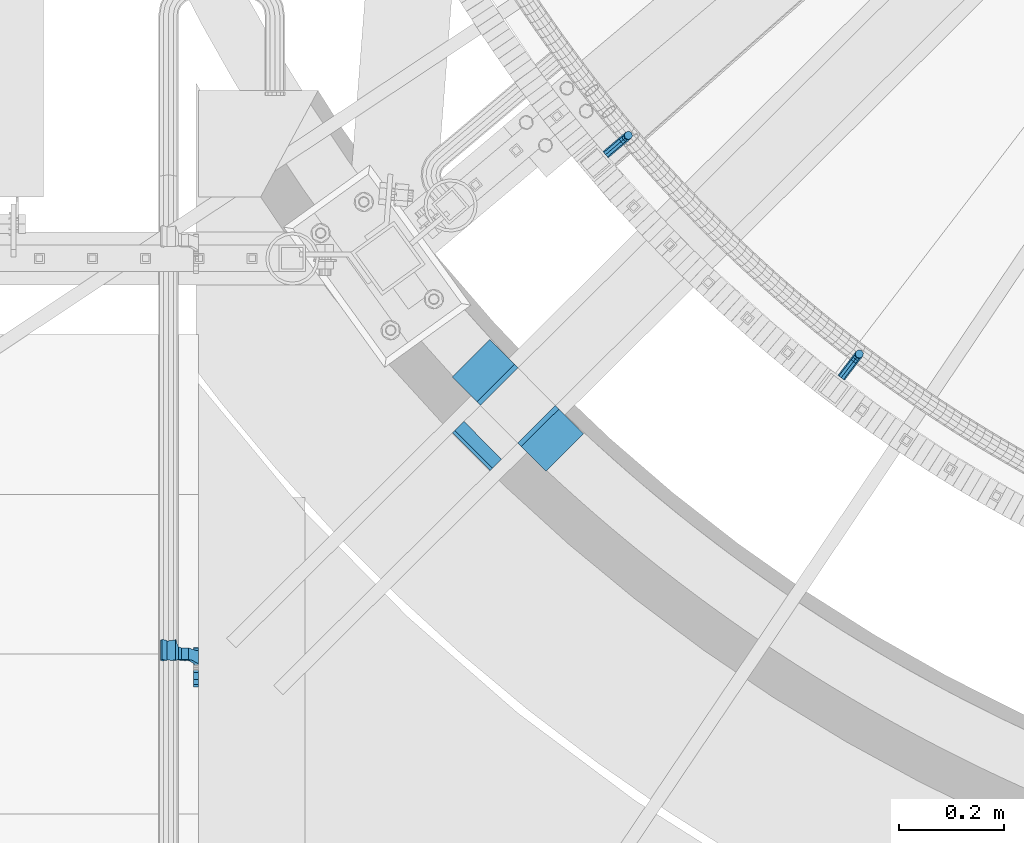
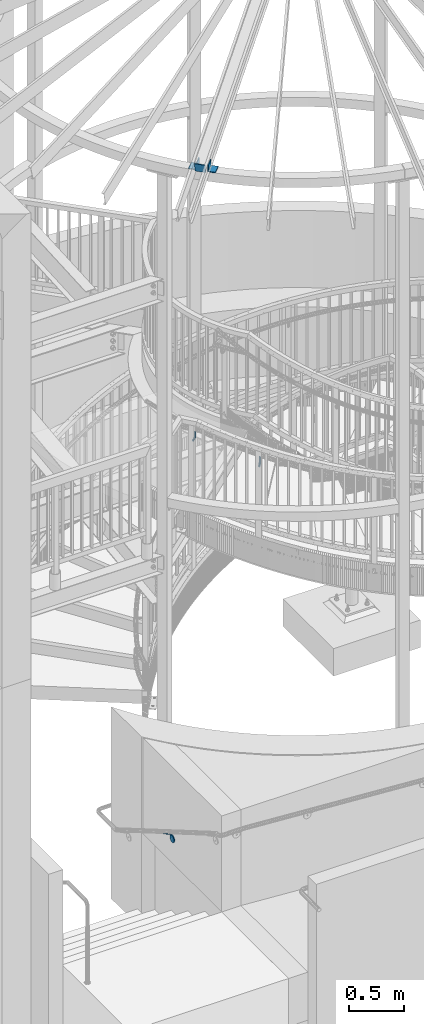
# One storey, part 461 of 975: 5 beams, 1 member.
"""IFC2X3 building model written with IfcOpenShell, lengths in millimetres."""

from ifc_helpers import new_model, si_unit, frame, origin_with_axes, place, context, subcontext, project, spatial, faceted_brep, material, type_object, element, save


model = new_model("IFC2X3")

# Units and contexts
model_context = context("Model", 3, precision=1e-05, world=origin_with_axes())
body_context = subcontext(model_context, "Body", "Model", "MODEL_VIEW")
ifc_project = project(units=[si_unit("LENGTHUNIT", "METRE", prefix="MILLI"), si_unit("AREAUNIT", "SQUARE_METRE"), si_unit("VOLUMEUNIT", "CUBIC_METRE"), si_unit("MASSUNIT", "GRAM", prefix="KILO"), si_unit("TIMEUNIT", "SECOND"), si_unit("PLANEANGLEUNIT", "RADIAN"), si_unit("SOLIDANGLEUNIT", "STERADIAN"), si_unit("THERMODYNAMICTEMPERATUREUNIT", "DEGREE_CELSIUS"), si_unit("LUMINOUSINTENSITYUNIT", "LUMEN")], contexts=[model_context])

# Site, building, storey
site_placement = place(None, origin_with_axes())
site = spatial("IfcSite", under=ifc_project, at=site_placement, CompositionType="ELEMENT")
building_placement = place(site_placement, origin_with_axes())
building = spatial("IfcBuilding", under=site, at=building_placement, Name="Undefined", CompositionType="ELEMENT")
storey_placement = place(building_placement, origin_with_axes())
storey = spatial("IfcBuildingStorey", under=building, at=storey_placement, Name="Undefined", CompositionType="ELEMENT", Elevation=0.0)

# Beams
ifc_material = material(Name="STEEL/A36")
beam_type_1 = type_object("IfcBeamType", PredefinedType="NOTDEFINED")
beam_1_placement = place(storey_placement, frame((32565.4851462999, 1562.87687980084, 4902.20901031494), z_axis=(0.0, 0.0, 1.0), x_axis=(0.762764145918276, 0.646676779930719, 0.0)))
element("IfcBeam", 1, at=beam_1_placement, inside=storey, type_object=beam_type_1, material=ifc_material, Name="BRACKET", context=body_context, shape_type="Brep", body=[
    faceted_brep([(-4.22995071858168e-07, -7.93750000000728, 0.0), (-2.99107341561466e-07, -5.61266007567065, -5.61266007566792), (31.7499842270954, -5.6126618385606, -5.6126600757234), (31.7499840980236, -7.93750176289177, -5.54791768081486e-11), (-1.09139364212751e-11, 1.81898940354586e-12, -7.9375), (31.7499845387247, -1.7628881323617e-06, -7.93750000005548), (2.99089151667431e-07, 5.61266007567428, -5.61266007566792), (31.7499848503612, 5.61265831278433, -5.6126600757234), (4.22980519942939e-07, 7.93750000001091, 0.0), (31.7499849794513, 7.93749823711914, -5.54791768081486e-11), (2.99089151667431e-07, 5.61266007567428, 5.61266007566792), (31.7499848503794, 5.61265831278433, 5.61266007561244), (-1.09139364212751e-11, 1.81898940354586e-12, 7.9375), (31.7499845387538, -1.7628881323617e-06, 7.93749999994452), (-2.99107341561466e-07, -5.61266007567065, 5.61266007566792), (31.7499842271172, -5.6126618385606, 5.61266007561244), (44.5076933192395, -2.47124626184814e-06, -5.39983394420233), (43.618015285665, -5.61266249752225, -3.25196192174644), (41.4701431341346, -7.93750230259684, 1.9334598451087), (39.322271240766, -5.61266225900181, 7.11888161196475), (38.432593830461, -2.1339365048334e-06, 9.26675363442064), (39.3222718640282, 5.61265789233948, 7.11888161196475), (41.4701440155623, 7.93749769741771, 1.9334598451087), (43.6180159089272, 5.61265765382268, -3.25196192174644), (53.6792468227941, 5.61265709518557, 3.47073764605557), (55.32315658683, -3.07176742353477e-06, 1.82682757038583), (49.7104969518768, 7.93749723988003, 7.43948764606012), (45.7417468228014, 5.61265753590487, 11.4082376460638), (44.0978364355033, -2.44848706643097e-06, 13.0521477217335), (45.7417461995356, -5.61266261544006, 11.4082376460638), (49.7104960704528, -7.93750276013816, 7.43948764606012), (53.6792461995283, -5.612663056163, 3.47073764605648), (60.4019463906188, 5.61265672191075, 13.5319685599115), (62.5498181014409, -3.47302193404175e-06, 12.6422908379673), (55.2165247528465, 7.93749693416248, 15.6798405823693), (50.0311028569122, 5.61265729774459, 17.8277126048279), (47.8832305228243, -2.65866765403189e-06, 18.7173903267721), (50.03110223365, -5.61266285360034, 17.8277126048279), (55.2165238714188, -7.93750306585207, 15.6798405823693), (60.4019457673567, -5.61266342943782, 13.5319685599115), (62.7626445446149, 5.61265659083438, 25.3999996184748), (65.0874841573168, -3.61392449121922e-06, 25.3999996184748), (57.1499845980288, 7.93749682680573, 25.3999996184748), (51.5373243932772, 5.61265721410746, 25.3999996184748), (49.2124841573132, -2.73247496807016e-06, 25.3999996184748), (51.5373237700151, -5.61266293723384, 25.3999996184748), (57.1499837166011, -7.93750317320519, 25.3999996184748), (62.7626439213527, -5.61266356051055, 25.3999996184748), (62.7626439213527, -5.61266356051055, 63.4909896850586), (57.1499837166011, -7.93750317320519, 63.4909896850586), (65.0874841573168, -3.61392449121922e-06, 63.4909896850586), (62.7626445446149, 5.61265659083438, 63.4909896850586), (57.1499845980288, 7.93749682680573, 63.4909896850586), (51.5373243932772, 5.61265721410746, 63.4909896850586), (49.2124841573132, -2.73247496807016e-06, 63.4909896850586), (51.5373237700151, -5.61266293723384, 63.4909896850586)], [[[0, 1, 2, 3]], [[1, 4, 5, 2]], [[4, 6, 7, 5]], [[6, 8, 9, 7]], [[8, 10, 11, 9]], [[10, 12, 13, 11]], [[12, 14, 15, 13]], [[14, 0, 3, 15]], [[14, 12, 10, 8, 6, 4, 1, 0]], [[2, 5, 16, 17]], [[3, 2, 17, 18]], [[15, 3, 18, 19]], [[13, 15, 19, 20]], [[11, 13, 20, 21]], [[9, 11, 21, 22]], [[7, 9, 22, 23]], [[5, 7, 23, 16]], [[23, 24, 25, 16]], [[22, 26, 24, 23]], [[21, 27, 26, 22]], [[20, 28, 27, 21]], [[19, 29, 28, 20]], [[18, 30, 29, 19]], [[17, 31, 30, 18]], [[16, 25, 31, 17]], [[24, 32, 33, 25]], [[26, 34, 32, 24]], [[27, 35, 34, 26]], [[28, 36, 35, 27]], [[29, 37, 36, 28]], [[30, 38, 37, 29]], [[31, 39, 38, 30]], [[25, 33, 39, 31]], [[32, 40, 41, 33]], [[34, 42, 40, 32]], [[35, 43, 42, 34]], [[36, 44, 43, 35]], [[37, 45, 44, 36]], [[38, 46, 45, 37]], [[39, 47, 46, 38]], [[33, 41, 47, 39]], [[46, 47, 48, 49]], [[47, 41, 50, 48]], [[41, 40, 51, 50]], [[40, 42, 52, 51]], [[42, 43, 53, 52]], [[43, 44, 54, 53]], [[44, 45, 55, 54]], [[45, 46, 49, 55]], [[50, 51, 52, 53, 54, 55, 49, 48]]]),
])
beam_2_placement = place(storey_placement, frame((33015.3091282994, 1137.04539276785, 4717.29684671675), z_axis=(0.0, 0.0, 1.0), x_axis=(0.604715621933626, 0.796441470912601, 0.0)))
element("IfcBeam", 2, at=beam_2_placement, inside=storey, type_object=beam_type_1, material=ifc_material, Name="BRACKET", context=body_context, shape_type="Brep", body=[
    faceted_brep([(-4.22995071858168e-07, -7.93750000000728, 0.0), (-2.99107341561466e-07, -5.61266007567065, -5.61266007566792), (31.7499842270954, -5.6126618385606, -5.6126600757234), (31.7499840980236, -7.93750176289177, -5.54791768081486e-11), (-1.09139364212751e-11, 1.81898940354586e-12, -7.9375), (31.7499845387247, -1.7628881323617e-06, -7.93750000005548), (2.99089151667431e-07, 5.61266007567428, -5.61266007566792), (31.7499848503612, 5.61265831278433, -5.6126600757234), (4.22980519942939e-07, 7.93750000001091, 0.0), (31.7499849794513, 7.93749823711914, -5.54791768081486e-11), (2.99089151667431e-07, 5.61266007567428, 5.61266007566792), (31.7499848503794, 5.61265831278433, 5.61266007561244), (-1.09139364212751e-11, 1.81898940354586e-12, 7.9375), (31.7499845387538, -1.7628881323617e-06, 7.93749999994452), (-2.99107341561466e-07, -5.61266007567065, 5.61266007566792), (31.7499842271172, -5.6126618385606, 5.61266007561244), (44.5076933192395, -2.47124626184814e-06, -5.39983394420233), (43.618015285665, -5.61266249752225, -3.25196192174644), (41.4701431341346, -7.93750230259684, 1.9334598451087), (39.322271240766, -5.61266225900181, 7.11888161196475), (38.432593830461, -2.1339365048334e-06, 9.26675363442064), (39.3222718640282, 5.61265789233948, 7.11888161196475), (41.4701440155623, 7.93749769741771, 1.9334598451087), (43.6180159089272, 5.61265765382268, -3.25196192174644), (53.6792468227941, 5.61265709518557, 3.47073764605557), (55.32315658683, -3.07176742353477e-06, 1.82682757038583), (49.7104969518768, 7.93749723988003, 7.43948764606012), (45.7417468228014, 5.61265753590487, 11.4082376460638), (44.0978364355033, -2.44848706643097e-06, 13.0521477217335), (45.7417461995356, -5.61266261544006, 11.4082376460638), (49.7104960704528, -7.93750276013816, 7.43948764606012), (53.6792461995283, -5.612663056163, 3.47073764605648), (60.4019463906188, 5.61265672191075, 13.5319685599115), (62.5498181014409, -3.47302193404175e-06, 12.6422908379673), (55.2165247528465, 7.93749693416248, 15.6798405823693), (50.0311028569122, 5.61265729774459, 17.8277126048279), (47.8832305228243, -2.65866765403189e-06, 18.7173903267721), (50.03110223365, -5.61266285360034, 17.8277126048279), (55.2165238714188, -7.93750306585207, 15.6798405823693), (60.4019457673567, -5.61266342943782, 13.5319685599115), (62.7626445446149, 5.61265659083438, 25.3999996184748), (65.0874841573168, -3.61392449121922e-06, 25.3999996184748), (57.1499845980288, 7.93749682680573, 25.3999996184748), (51.5373243932772, 5.61265721410746, 25.3999996184748), (49.2124841573132, -2.73247496807016e-06, 25.3999996184748), (51.5373237700151, -5.61266293723384, 25.3999996184748), (57.1499837166011, -7.93750317320519, 25.3999996184748), (62.7626439213527, -5.61266356051055, 25.3999996184748), (65.0874827799671, -8.13710357761011e-07, 63.5532656203741), (62.7626427854739, -5.61266086031537, 61.7133802904182), (57.1499826807376, -7.93750071448449, 60.9512776088477), (51.5373226341253, -5.61266071998034, 61.7133869906074), (49.2124827799453, -6.15244061918929e-07, 63.5532750958728), (51.5373227744385, 5.61265943136095, 65.3931604258296), (57.1499828791711, 7.93749928552643, 66.1552631073992), (62.7626429257907, 5.61265929102228, 65.3931537256394)], [[[0, 1, 2, 3]], [[1, 4, 5, 2]], [[4, 6, 7, 5]], [[6, 8, 9, 7]], [[8, 10, 11, 9]], [[10, 12, 13, 11]], [[12, 14, 15, 13]], [[14, 0, 3, 15]], [[14, 12, 10, 8, 6, 4, 1, 0]], [[2, 5, 16, 17]], [[3, 2, 17, 18]], [[15, 3, 18, 19]], [[13, 15, 19, 20]], [[11, 13, 20, 21]], [[9, 11, 21, 22]], [[7, 9, 22, 23]], [[5, 7, 23, 16]], [[23, 24, 25, 16]], [[22, 26, 24, 23]], [[21, 27, 26, 22]], [[20, 28, 27, 21]], [[19, 29, 28, 20]], [[18, 30, 29, 19]], [[17, 31, 30, 18]], [[16, 25, 31, 17]], [[24, 32, 33, 25]], [[26, 34, 32, 24]], [[27, 35, 34, 26]], [[28, 36, 35, 27]], [[29, 37, 36, 28]], [[30, 38, 37, 29]], [[31, 39, 38, 30]], [[25, 33, 39, 31]], [[32, 40, 41, 33]], [[34, 42, 40, 32]], [[35, 43, 42, 34]], [[36, 44, 43, 35]], [[37, 45, 44, 36]], [[38, 46, 45, 37]], [[39, 47, 46, 38]], [[33, 41, 47, 39]], [[47, 41, 48, 49]], [[46, 47, 49, 50]], [[45, 46, 50, 51]], [[44, 45, 51, 52]], [[43, 44, 52, 53]], [[42, 43, 53, 54]], [[40, 42, 54, 55]], [[41, 40, 55, 48]], [[54, 53, 52, 51, 50, 49, 48, 55]]]),
])
beam_type_2 = type_object("IfcBeamType", PredefinedType="NOTDEFINED")
beam_3_placement = place(storey_placement, frame((31778.574969517, 584.115426840513, 1343.95647607834), z_axis=(0.0, -0.863778825965781, 0.50387115398004), x_axis=(1.0, 0.0, 0.0)))
element("IfcBeam", 3, at=beam_3_placement, inside=storey, type_object=beam_type_2, material=ifc_material, Name="WALL BRACKET", context=body_context, shape_type="Brep", body=[
    faceted_brep([(-1.09139364212751e-11, -35.1998101886752, 14.5802387730655), (0.0, -26.940768363208, 26.9407683632162), (1.2732925824821e-11, -14.5802387731151, 35.1998101887366), (0.0, 0.0, 38.0999984741211), (3.27418092638254e-11, 14.5802387730973, 35.1998101888166), (3.45607986673713e-11, 26.9407683631939, 26.9407683633472), (3.27418092638254e-11, 35.1998101886679, 14.5802387732328), (2.36468622460961e-11, 38.0999999999908, 8.73114913702011e-11), (1.45519152283669e-11, 35.1998101886752, -14.5802387730655), (1.81898940354586e-12, 26.9407683632071, -26.9407683632162), (-1.09139364212751e-11, 14.5802387731146, -35.1998101887511), (0.0, 0.0, -38.0999984741211), (-2.91038304567337e-11, -14.5802387730978, -35.1998101888239), (-3.27418092638254e-11, -26.9407683631948, -26.9407683633617), (-3.09228198602796e-11, -35.1998101886688, -14.5802387732401), (-2.36468622460961e-11, -38.0999999999917, -9.45874489843845e-11), (9.52499999999407, 35.4440469783465, 13.3523775149006), (9.52500000001783, 38.099999999989, 1.23691279441118e-10), (5.45819490078651, 35.1998101886775, 14.58023877304), (5.15915812204861, 35.4440469814256, 13.3523774994246), (5.15916016817869, 35.4440461871586, -13.3523814925829), (5.45819607316758, 35.1998101886757, -14.5802387731565), (9.52499999563867, 35.4440461839649, -13.352381508641), (9.52499999999338, 33.7468954266617, -16.754679378646), (9.52499999999418, 26.9407683632057, -26.9407683631944), (7.23710514487385, 33.7468954167059, -16.7546793935435), (9.52499999997963, 14.5802387731133, -35.199810188722), (9.52499999996871, 7.73070496506989e-12, -38.1000000000931), (9.52499999996326, -14.5802387730996, -35.1998101888021), (9.52499999995962, -26.9407683631966, -26.9407683633399), (9.5249999999578, -35.1998101886768, -14.5802387731064), (9.52499999997235, -38.0999999999935, -7.27595761418343e-11), (9.52499999988504, -35.1998101886779, 14.5802387731401), (9.52499999999418, -26.9407683632098, 26.940768363238), (9.52500000000691, -14.5802387731169, 35.1998101887584), (9.52500000001783, -1.13686837721616e-11, 38.1000000001295), (9.5250000000251, 14.580238773096, 35.1998101888312), (9.52500000002692, 26.9407683631925, 26.9407683633617), (7.23710629084189, 33.7468933804012, 16.7546824409801), (9.52500001802099, 33.74689339, 16.7546824266137), (4.12737783423069, 36.2867482851609, 11.6630037101459), (9.52500001480979, 36.2867482910076, 11.6630037099276), (1.9072828969438, 38.0999998001848, -4.3824766180478e-06), (9.43529109937867, 38.0999998083389, -4.38277129433118e-06), (4.12738199474541, 36.2867456530334, -11.6630120660157), (9.52499999713365, 36.2867456588801, -11.6630120662267), (9.52499998931302, 31.8782691818908, -20.5007361535354), (1.90728516843444, 38.0999984362613, -14.9620414784949), (9.43529504267332, 38.0999984471014, -14.9620414798228), (9.52499998867484, 31.8782692100656, -21.3428983101403), (-0.974480980704527, 40.4536660864392, -13.6176374922397), (6.55352889353486, 40.4536660972792, -13.617637493564), (-3.23293929398841, 48.4467136552532, -12.2071016444133), (-3.86099316375032, 48.9596734302611, -12.3332393299024), (-3.86099415506237, 48.9596734359397, 12.1506042690053), (-3.23294234398753, 48.4467162038179, 12.0244673261113), (6.55352388489973, 40.4536689343606, 13.4350048968336), (9.4352891744017, 38.1000015670843, 14.7794093900302), (-8.88876894391092, 51.462646060533, -12.9487245784876), (-14.5044020842531, 51.5524567377918, -12.9708091785214), (-14.5044031272276, 51.5524567437842, 12.788173508583), (-8.88876998507754, 51.4626460665079, 12.7660889411018), (-16.4483770195459, 51.1442726592504, -12.8704360163174), (-16.4483780543928, 51.1442726651987, 12.6878004343525), (-22.5793182144077, 51.3711360271759, -12.9262221073186), (-22.5793192537777, 51.3711360331463, 12.7435864607032), (-27.8885284154861, 54.4455780358899, -13.6822326528272), (-27.8885295160832, 54.4455780422152, 13.4995963000001), (-28.6196515649072, 55.6169452716154, -13.9702738582564), (-31.1370083013608, 59.6501226213948, -17.5950925222933), (-31.1370097188383, 59.6501226295447, 17.4124524185645), (-28.6196545294583, 55.616948227025, 13.7876379643458), (-33.6296792490059, 67.324805151891, -22.2250062266612), (-32.8101722890036, 64.8016260361878, -22.2250061928717), (-39.3161821982224, 64.9509398614337, -22.2250064563596), (-33.6296810489844, 67.3248051619378, 22.2249937734341), (-39.3127719838823, 64.95236112884, 22.2249935438595), (-32.8101756191698, 64.8016307577993, 22.2249938072164), (-49.8281982508399, 63.7590297560901, -21.2879733583577), (-49.8281999673757, 63.7590297658239, 21.1053316176076), (-62.537662592724, 64.8016282183019, -22.2250073966388), (-62.5376643923654, 64.8016282284259, 22.2249926034456), (-59.3629825026719, 68.3509998487543, 22.2249927311568), (-59.3629807030303, 68.3509998386305, -22.2250072689349), (-56.0005505059879, 61.6533412669896, 22.2249928688907), (-56.0009816237271, 61.6535489521873, 19.2130312653135), (-56.0009816302269, 64.8016307505561, 22.0423689734525), (-51.9930603186979, 64.8016307660225, 22.2249930304133), (-51.9930486616773, 64.8016260085653, -22.2250069696784), (-56.000981616694, 61.6535497473442, -22.2250071312228), (-56.0009816212363, 64.8016260027941, -22.2250068759422), (-56.0009816161877, 61.6535496925769, -19.3956728877092), (-50.6240356350016, 59.0640018412871, -17.0683164176735), (-50.6240370098228, 59.0640018490833, 16.8856764812081), (-37.4851004069614, 60.555058921409, -18.4084041452843), (-37.4851018904596, 60.555058929803, 18.2257636742615), (-36.5628425975134, 60.9400579463424, -18.7544220673662), (-36.5628441090176, 60.9400579547794, 18.5717814508498), (-35.6661101826384, 58.1791091500552, -16.2730189810172), (-35.6661114930633, 58.1791091575863, 16.0903794298065), (-34.0669073739811, 55.616948225869, 13.7876379531408), (-34.0669044052501, 55.6169452637716, -13.9702738572996), (-31.199578137138, 51.0230652214489, -12.8406309028251), (-31.1995791695818, 51.0230652273826, 12.6579953160217), (-13.5258453474495, 46.8920843628518, -12.4814476045976), (-10.0158535806146, 46.8359491542703, -12.491353805628), (-10.0158545847443, 46.8359491600327, 12.308720278641), (-13.5258463507973, 46.8920843686235, 12.298814059428), (-15.4698202757649, 46.4839002842855, -12.5534799881534), (-15.469821284944, 46.4839002900824, 12.3708465294185), (-23.8996230795056, 46.7958284847284, -12.4984339079674), (-23.8996240842331, 46.7958284904998, 12.3158003666576), (-26.7505131823156, 48.4467136213889, -12.207101640266), (-26.7505186046602, 48.4467161988273, 12.0244672777189), (-6.87329577845111, 45.2714927334573, -12.7674339683217), (-6.87329680492121, 45.2714927393397, 12.584800790275), (-0.974485553301008, 40.4536689327629, 13.4350048813394), (1.90728014135857, 38.100001565487, 14.7794093745397), (9.52500002100476, 31.8782677827221, 21.320715892205), (9.52500002038346, 31.878267810155, 20.5007393728483)], [[[0, 1, 2, 3, 4, 5, 6, 7, 8, 9, 10, 11, 12, 13, 14, 15]], [[16, 17, 7, 6, 18, 19]], [[20, 21, 8, 7, 17, 22]], [[23, 24, 9, 8, 21, 25]], [[10, 9, 24, 26]], [[11, 10, 26, 27]], [[12, 11, 27, 28]], [[13, 12, 28, 29]], [[14, 13, 29, 30]], [[15, 14, 30, 31]], [[0, 15, 31, 32]], [[1, 0, 32, 33]], [[2, 1, 33, 34]], [[3, 2, 34, 35]], [[4, 3, 35, 36]], [[5, 4, 36, 37]], [[38, 18, 6, 5, 37, 39]], [[39, 37, 36, 35, 34, 33, 32, 31, 30, 29, 28, 27, 26, 24, 23, 22, 17, 16]], [[40, 41, 16, 19]], [[40, 42, 43, 41]], [[42, 44, 45, 43]], [[46, 23, 25]], [[47, 48, 49]], [[48, 47, 50, 51]], [[51, 52, 53, 54, 55, 56, 57, 48]], [[58, 59, 60, 61]], [[59, 62, 63, 60]], [[62, 64, 65, 63]], [[64, 66, 67, 65]], [[66, 68, 69, 70, 71, 67]], [[72, 73, 74]], [[75, 76, 77]], [[74, 76, 75, 72]], [[74, 78, 79, 76]], [[80, 81, 82, 83]], [[84, 85, 86]], [[82, 81, 84, 86, 87]], [[78, 88, 83, 82, 87, 79]], [[89, 80, 83, 88, 90]], [[89, 90, 91]], [[84, 81, 80, 89, 91, 92, 93, 85]], [[92, 94, 95, 93]], [[94, 96, 97, 95]], [[96, 98, 99, 97]], [[70, 77, 76, 79, 87, 86, 85, 93, 95, 97, 99, 100, 71]], [[69, 73, 72, 75, 77, 70]], [[68, 101, 98, 96, 94, 92, 91, 90, 88, 78, 74, 73, 69]], [[99, 98, 101, 102, 103, 100]], [[104, 105, 106, 107]], [[108, 104, 107, 109]], [[110, 108, 109, 111]], [[103, 102, 112, 110, 111, 113]], [[54, 61, 60, 63, 65, 67, 71, 100, 103, 113, 55]], [[53, 58, 61, 54]], [[52, 112, 102, 101, 68, 66, 64, 62, 59, 58, 53]], [[51, 50, 114, 105, 104, 108, 110, 112, 52]], [[105, 114, 115, 106]], [[55, 113, 111, 109, 107, 106, 115, 116, 56]], [[56, 116, 117, 57]], [[117, 118, 57]], [[39, 16, 41, 43, 45, 22, 23, 46, 49, 48, 57, 118, 119]], [[119, 38, 39]], [[119, 118, 117, 116, 115, 114, 50, 47, 49, 46, 25, 21, 20, 44, 42, 40, 19, 18, 38]], [[45, 44, 20, 22]]]),
])
beam_type_3 = type_object("IfcBeamType", Name="L3X3X3/8", PredefinedType="NOTDEFINED")
for number, where, z_axis, x_axis, name in (
    (4, (32496.7457162768, 1057.10879702224, 8318.5), (0.704511181200146, -0.709692888201633, 9.99996585983236e-10), (-0.709692888126233, -0.7045111812761, 5.71955752093346e-10), "ANGLE"),
    (5, (32299.6068568301, 1111.48413860585, 8318.5), (-0.704511181200153, 0.709692888201625, 9.99996585988633e-10), (0.709692888126235, 0.704511181276098, 5.71968485019169e-10), "ANGLE"),
):
    element("IfcBeam", number, at=place(storey_placement, frame(where, z_axis=z_axis, x_axis=x_axis)), inside=storey, type_object=beam_type_3, material=ifc_material, Name=name, ObjectType="L3X3X3/8", context=body_context, shape_type="Brep", body=[
        faceted_brep([(-6.18456397205591e-11, 38.0999999999876, -38.1000000000258), (1.45519152283669e-10, 38.1000000000295, 38.1000000000386), (101.599999999788, 38.1000000000004, 38.0999999999767), (101.599999999762, 38.1000000000004, -38.1000000000313), (4.72937244921923e-11, 28.5749999999316, 38.1), (101.599999999788, 28.5750000000007, 38.0999999999767), (4.72937244921923e-11, 28.5749999999316, -28.575), (101.599999999766, 28.5750000000007, -28.5750000000298), (-5.0931703299284e-11, -38.0999999999112, -28.575), (101.599999999766, -38.1000000000004, -28.5750000000298), (-1.41881173476577e-10, -38.1000000000258, -38.1000000000386), (101.599999999762, -38.1000000000004, -38.1000000000313)], [[[0, 1, 2, 3]], [[1, 4, 5, 2]], [[4, 6, 7, 5]], [[6, 8, 9, 7]], [[8, 10, 11, 9]], [[10, 0, 3, 11]], [[5, 7, 9, 11, 3, 2]], [[10, 8, 6, 4, 1, 0]]]),
    ])

# Member
member_type = type_object("IfcMemberType", PredefinedType="NOTDEFINED")
member_placement = place(storey_placement, frame((32328.8646979674, 1015.52905498319, 8306.81398391972), z_axis=(0.704511181200146, -0.709692888201633, 9.99996585983236e-10), x_axis=(-0.17213026717781, -0.170873527176511, 0.970140922150774)))
element("IfcMember", 6, at=member_placement, inside=storey, type_object=member_type, material=ifc_material, Name="PLATE", context=body_context, shape_type="Brep", body=[
    faceted_brep([(0.0, 3.17499999999927, -50.7999999999993), (0.0, 3.17499999999109, 50.7999992370678), (101.600000000738, 3.17500000004657, 50.7999999999374), (101.600000000827, 3.17500000007567, -50.800000000112), (0.0, -3.17500000000882, 50.7999992370605), (101.60000000074, -3.17499999995562, 50.7999999999411), (0.0, -3.17499999999927, -50.7999999999993), (101.60000000083, -3.17499999993379, -50.8000000001084)], [[[0, 1, 2, 3]], [[1, 4, 5, 2]], [[4, 6, 7, 5]], [[6, 0, 3, 7]], [[5, 7, 3, 2]], [[6, 4, 1, 0]]]),
])

save(model, "model.ifc")
